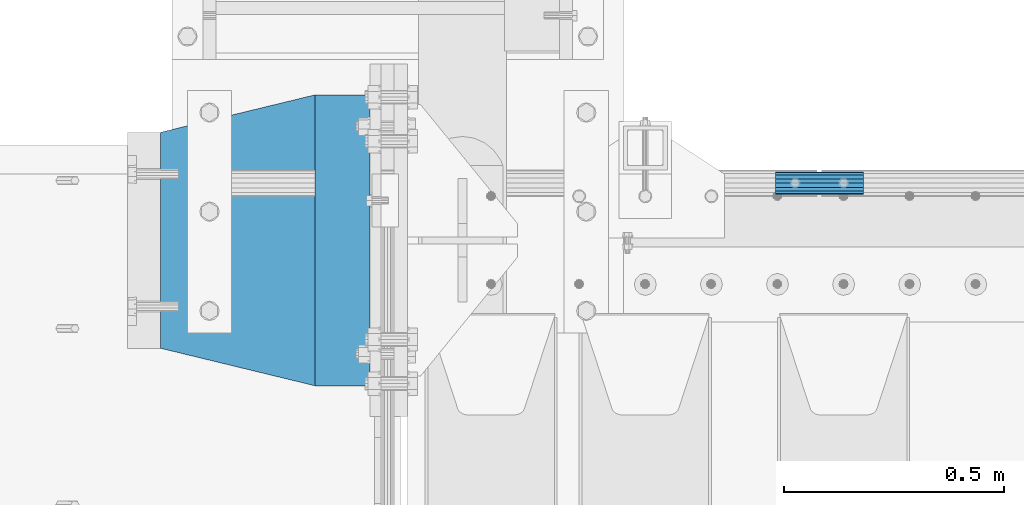
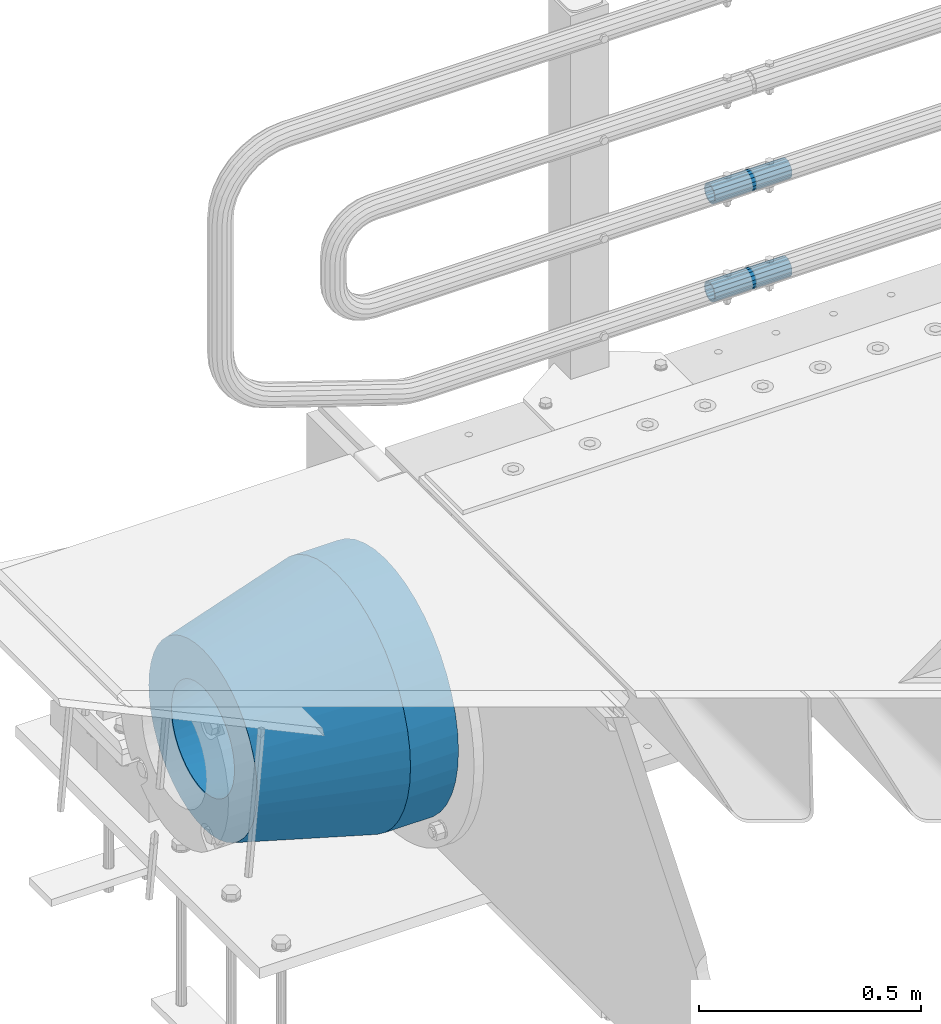
# One storey, part 152 of 257: 4 beams.
"""IFC2X3 building model written with IfcOpenShell, lengths in millimetres."""

from ifc_helpers import new_model, si_unit, frame, origin_with_axes, place, context, subcontext, project, spatial, faceted_brep, material, type_object, element, save


model = new_model("IFC2X3")

# Units and contexts
model_context = context("Model", 3, precision=1e-05, world=origin_with_axes())
body_context = subcontext(model_context, "Body", "Model", "MODEL_VIEW")
ifc_project = project(units=[si_unit("LENGTHUNIT", "METRE", prefix="MILLI"), si_unit("AREAUNIT", "SQUARE_METRE"), si_unit("VOLUMEUNIT", "CUBIC_METRE"), si_unit("MASSUNIT", "GRAM", prefix="KILO"), si_unit("TIMEUNIT", "SECOND"), si_unit("PLANEANGLEUNIT", "RADIAN"), si_unit("SOLIDANGLEUNIT", "STERADIAN"), si_unit("THERMODYNAMICTEMPERATUREUNIT", "DEGREE_CELSIUS"), si_unit("LUMINOUSINTENSITYUNIT", "LUMEN")], contexts=[model_context])

# Site, building, storey
site_placement = place(None, origin_with_axes())
site = spatial("IfcSite", under=ifc_project, at=site_placement, CompositionType="ELEMENT")
building_placement = place(site_placement, origin_with_axes())
building = spatial("IfcBuilding", under=site, at=building_placement, Name="Standard", CompositionType="ELEMENT")
storey_placement = place(building_placement, origin_with_axes())
storey = spatial("IfcBuildingStorey", under=building, at=storey_placement, Name="Undefined", CompositionType="ELEMENT", Elevation=0.0)

# Beams
ifc_material_1 = material()
beam_type_1 = type_object("IfcBeamType", PredefinedType="NOTDEFINED")
beam_1_placement = place(storey_placement, frame((43294.9975029999, 12129.8500000004, 149.849999999725), z_axis=(0.0, 0.0, 1.0), x_axis=(1.0, 0.0, 0.0)))
element("IfcBeam", 1, at=beam_1_placement, inside=storey, type_object=beam_type_1, material=ifc_material_1, context=body_context, shape_type="Brep", body=[
    faceted_brep([(0.0, -21.8999999999996, 0.0), (0.0, -20.232961761998, 8.38076716879547), (200.0, -20.232961761998, 8.38076716879547), (200.0, -21.8999999999996, 0.0), (0.0, -15.4856385079856, 15.4856385079854), (200.0, -15.4856385079856, 15.4856385079854), (0.0, -8.3807671687955, 20.2329617619972), (200.0, -8.3807671687955, 20.2329617619972), (0.0, 0.0, 21.9), (200.0, 0.0, 21.9), (0.0, 8.3807671687955, 20.2329617619972), (200.0, 8.3807671687955, 20.2329617619972), (0.0, 15.4856385079856, 15.4856385079854), (200.0, 15.4856385079856, 15.4856385079854), (0.0, 20.232961761998, 8.38076716879547), (200.0, 20.232961761998, 8.38076716879547), (0.0, 21.8999999999996, 0.0), (200.0, 21.8999999999996, 0.0), (0.0, 20.232961761998, -8.38076716879547), (200.0, 20.232961761998, -8.38076716879547), (0.0, 15.4856385079856, -15.4856385079854), (200.0, 15.4856385079856, -15.4856385079854), (0.0, 8.3807671687955, -20.2329617619972), (200.0, 8.3807671687955, -20.2329617619972), (0.0, 0.0, -21.9), (200.0, 0.0, -21.9), (0.0, -8.3807671687955, -20.2329617619972), (200.0, -8.3807671687955, -20.2329617619972), (0.0, -15.4856385079856, -15.4856385079854), (200.0, -15.4856385079856, -15.4856385079854), (0.0, -20.232961761998, -8.38076716879547), (200.0, -20.232961761998, -8.38076716879547), (0.0, -25.5, 0.0), (0.0, -23.5589280790373, -9.7584275253098), (200.0, -23.5589280790373, -9.7584275253098), (200.0, -25.5, 0.0), (0.0, -18.0312229202573, -18.031222920257), (200.0, -18.0312229202573, -18.031222920257), (0.0, -9.75842752531025, -23.5589280790378), (200.0, -9.75842752531025, -23.5589280790378), (0.0, 0.0, -25.5), (200.0, 0.0, -25.5), (0.0, 9.75842752531025, -23.5589280790378), (200.0, 9.75842752531025, -23.5589280790378), (0.0, 18.0312229202573, -18.031222920257), (200.0, 18.0312229202573, -18.031222920257), (0.0, 23.5589280790373, -9.7584275253098), (200.0, 23.5589280790373, -9.7584275253098), (0.0, 25.5, 0.0), (200.0, 25.5, 0.0), (0.0, 23.5589280790373, 9.7584275253098), (200.0, 23.5589280790373, 9.7584275253098), (0.0, 18.0312229202573, 18.031222920257), (200.0, 18.0312229202573, 18.031222920257), (0.0, 9.75842752531025, 23.5589280790378), (200.0, 9.75842752531025, 23.5589280790378), (0.0, 0.0, 25.5), (200.0, 0.0, 25.5), (0.0, -9.75842752531025, 23.5589280790378), (200.0, -9.75842752531025, 23.5589280790378), (0.0, -18.0312229202573, 18.031222920257), (200.0, -18.0312229202573, 18.031222920257), (0.0, -23.5589280790373, 9.7584275253098), (200.0, -23.5589280790373, 9.7584275253098)], [[[0, 1, 2, 3]], [[1, 4, 5, 2]], [[4, 6, 7, 5]], [[6, 8, 9, 7]], [[8, 10, 11, 9]], [[10, 12, 13, 11]], [[12, 14, 15, 13]], [[14, 16, 17, 15]], [[16, 18, 19, 17]], [[18, 20, 21, 19]], [[20, 22, 23, 21]], [[22, 24, 25, 23]], [[24, 26, 27, 25]], [[26, 28, 29, 27]], [[28, 30, 31, 29]], [[30, 0, 3, 31]], [[32, 33, 34, 35]], [[33, 36, 37, 34]], [[36, 38, 39, 37]], [[38, 40, 41, 39]], [[40, 42, 43, 41]], [[42, 44, 45, 43]], [[44, 46, 47, 45]], [[46, 48, 49, 47]], [[48, 50, 51, 49]], [[50, 52, 53, 51]], [[52, 54, 55, 53]], [[54, 56, 57, 55]], [[56, 58, 59, 57]], [[58, 60, 61, 59]], [[60, 62, 63, 61]], [[62, 32, 35, 63]], [[37, 39, 41, 43, 45, 47, 49, 51, 53, 55, 57, 59, 61, 63, 35, 34], [5, 7, 9, 11, 13, 15, 17, 19, 21, 23, 25, 27, 29, 31, 3, 2]], [[62, 60, 58, 56, 54, 52, 50, 48, 46, 44, 42, 40, 38, 36, 33, 32], [30, 28, 26, 24, 22, 20, 18, 16, 14, 12, 10, 8, 6, 4, 1, 0]]]),
])
beam_2_placement = place(storey_placement, frame((43294.9975029999, 12129.8500000004, 420.149999999724), z_axis=(0.0, 0.0, 1.0), x_axis=(1.0, 0.0, 0.0)))
element("IfcBeam", 2, at=beam_2_placement, inside=storey, type_object=beam_type_1, material=ifc_material_1, context=body_context, shape_type="Brep", body=[
    faceted_brep([(0.0, -21.8999999999996, 0.0), (0.0, -20.232961761998, 8.38076716879547), (200.0, -20.232961761998, 8.38076716879547), (200.0, -21.8999999999996, 0.0), (0.0, -15.4856385079856, 15.4856385079854), (200.0, -15.4856385079856, 15.4856385079854), (0.0, -8.3807671687955, 20.2329617619972), (200.0, -8.3807671687955, 20.2329617619972), (0.0, 0.0, 21.9), (200.0, 0.0, 21.9), (0.0, 8.3807671687955, 20.2329617619972), (200.0, 8.3807671687955, 20.2329617619972), (0.0, 15.4856385079856, 15.4856385079854), (200.0, 15.4856385079856, 15.4856385079854), (0.0, 20.232961761998, 8.38076716879547), (200.0, 20.232961761998, 8.38076716879547), (0.0, 21.8999999999996, 0.0), (200.0, 21.8999999999996, 0.0), (0.0, 20.232961761998, -8.38076716879547), (200.0, 20.232961761998, -8.38076716879547), (0.0, 15.4856385079856, -15.4856385079854), (200.0, 15.4856385079856, -15.4856385079854), (0.0, 8.3807671687955, -20.2329617619972), (200.0, 8.3807671687955, -20.2329617619972), (0.0, 0.0, -21.9), (200.0, 0.0, -21.9), (0.0, -8.3807671687955, -20.2329617619972), (200.0, -8.3807671687955, -20.2329617619972), (0.0, -15.4856385079856, -15.4856385079854), (200.0, -15.4856385079856, -15.4856385079854), (0.0, -20.232961761998, -8.38076716879547), (200.0, -20.232961761998, -8.38076716879547), (0.0, -25.5, 0.0), (0.0, -23.5589280790373, -9.7584275253098), (200.0, -23.5589280790373, -9.7584275253098), (200.0, -25.5, 0.0), (0.0, -18.0312229202573, -18.031222920257), (200.0, -18.0312229202573, -18.031222920257), (0.0, -9.75842752531025, -23.5589280790378), (200.0, -9.75842752531025, -23.5589280790378), (0.0, 0.0, -25.5), (200.0, 0.0, -25.5), (0.0, 9.75842752531025, -23.5589280790378), (200.0, 9.75842752531025, -23.5589280790378), (0.0, 18.0312229202573, -18.031222920257), (200.0, 18.0312229202573, -18.031222920257), (0.0, 23.5589280790373, -9.7584275253098), (200.0, 23.5589280790373, -9.7584275253098), (0.0, 25.5, 0.0), (200.0, 25.5, 0.0), (0.0, 23.5589280790373, 9.7584275253098), (200.0, 23.5589280790373, 9.7584275253098), (0.0, 18.0312229202573, 18.031222920257), (200.0, 18.0312229202573, 18.031222920257), (0.0, 9.75842752531025, 23.5589280790378), (200.0, 9.75842752531025, 23.5589280790378), (0.0, 0.0, 25.5), (200.0, 0.0, 25.5), (0.0, -9.75842752531025, 23.5589280790378), (200.0, -9.75842752531025, 23.5589280790378), (0.0, -18.0312229202573, 18.031222920257), (200.0, -18.0312229202573, 18.031222920257), (0.0, -23.5589280790373, 9.7584275253098), (200.0, -23.5589280790373, 9.7584275253098)], [[[0, 1, 2, 3]], [[1, 4, 5, 2]], [[4, 6, 7, 5]], [[6, 8, 9, 7]], [[8, 10, 11, 9]], [[10, 12, 13, 11]], [[12, 14, 15, 13]], [[14, 16, 17, 15]], [[16, 18, 19, 17]], [[18, 20, 21, 19]], [[20, 22, 23, 21]], [[22, 24, 25, 23]], [[24, 26, 27, 25]], [[26, 28, 29, 27]], [[28, 30, 31, 29]], [[30, 0, 3, 31]], [[32, 33, 34, 35]], [[33, 36, 37, 34]], [[36, 38, 39, 37]], [[38, 40, 41, 39]], [[40, 42, 43, 41]], [[42, 44, 45, 43]], [[44, 46, 47, 45]], [[46, 48, 49, 47]], [[48, 50, 51, 49]], [[50, 52, 53, 51]], [[52, 54, 55, 53]], [[54, 56, 57, 55]], [[56, 58, 59, 57]], [[58, 60, 61, 59]], [[60, 62, 63, 61]], [[62, 32, 35, 63]], [[37, 39, 41, 43, 45, 47, 49, 51, 53, 55, 57, 59, 61, 63, 35, 34], [5, 7, 9, 11, 13, 15, 17, 19, 21, 23, 25, 27, 29, 31, 3, 2]], [[62, 60, 58, 56, 54, 52, 50, 48, 46, 44, 42, 40, 38, 36, 33, 32], [30, 28, 26, 24, 22, 20, 18, 16, 14, 12, 10, 8, 6, 4, 1, 0]]]),
])
ifc_material_2 = material(Name="STEEL/S355N")
beam_type_2 = type_object("IfcBeamType", PredefinedType="NOTDEFINED")
beam_3_placement = place(storey_placement, frame((42375.0, 12000.0, -515.0), z_axis=(0.0, 0.0, 1.0), x_axis=(-1.0, 0.0, 0.0)))
element("IfcBeam", 3, at=beam_3_placement, inside=storey, type_object=beam_type_2, material=ifc_material_2, context=body_context, shape_type="Brep", body=[
    faceted_brep([(0.0, -215.0, 0.0), (0.0, -212.811610004401, 30.5976902287563), (125.0, -212.811610004401, 30.5976902287563), (125.0, -215.0, 0.0), (0.0, -206.290989327117, 60.5724997209074), (125.0, -206.290989327117, 60.5724997209074), (0.0, -195.570879001221, 89.3142277954056), (125.0, -195.570879001221, 89.3142277954056), (0.0, -180.869509558704, 116.237775752953), (125.0, -180.869509558704, 116.237775752953), (0.0, -162.486158486166, 140.795057798236), (125.0, -162.486158486166, 140.795057798236), (0.0, -140.795057798236, 162.486158486165), (125.0, -140.795057798236, 162.486158486165), (0.0, -116.237775752953, 180.869509558704), (125.0, -116.237775752953, 180.869509558704), (0.0, -89.3142277954055, 195.570879001222), (125.0, -89.3142277954055, 195.570879001222), (0.0, -60.5724997209073, 206.290989327117), (125.0, -60.5724997209073, 206.290989327117), (0.0, -30.5976902287562, 212.811610004401), (125.0, -30.5976902287562, 212.811610004401), (0.0, 3.94948592725021e-14, 215.0), (125.0, 3.94948592725021e-14, 215.0), (0.0, 30.5976902287563, 212.811610004401), (125.0, 30.5976902287563, 212.811610004401), (0.0, 60.5724997209074, 206.290989327117), (125.0, 60.5724997209074, 206.290989327117), (0.0, 89.3142277954056, 195.570879001221), (125.0, 89.3142277954056, 195.570879001221), (0.0, 116.237775752953, 180.869509558704), (125.0, 116.237775752953, 180.869509558704), (0.0, 140.795057798236, 162.486158486165), (125.0, 140.795057798236, 162.486158486165), (0.0, 162.486158486166, 140.795057798236), (125.0, 162.486158486166, 140.795057798236), (0.0, 180.869509558704, 116.237775752953), (125.0, 180.869509558704, 116.237775752953), (0.0, 195.570879001221, 89.3142277954056), (125.0, 195.570879001221, 89.3142277954056), (0.0, 206.290989327117, 60.5724997209073), (125.0, 206.290989327117, 60.5724997209073), (0.0, 212.811610004401, 30.5976902287563), (125.0, 212.811610004401, 30.5976902287563), (0.0, 215.0, 0.0), (125.0, 215.0, 0.0), (0.0, 212.811610004401, -30.5976902287563), (125.0, 212.811610004401, -30.5976902287563), (0.0, 206.290989327117, -60.5724997209073), (125.0, 206.290989327117, -60.5724997209073), (0.0, 195.570879001221, -89.3142277954056), (125.0, 195.570879001221, -89.3142277954056), (0.0, 180.869509558704, -116.237775752954), (125.0, 180.869509558704, -116.237775752954), (0.0, 162.486158486165, -140.795057798236), (125.0, 162.486158486165, -140.795057798236), (0.0, 140.795057798236, -162.486158486166), (125.0, 140.795057798236, -162.486158486166), (0.0, 116.237775752953, -180.869509558704), (125.0, 116.237775752953, -180.869509558704), (0.0, 89.3142277954056, -195.570879001221), (125.0, 89.3142277954056, -195.570879001221), (0.0, 60.5724997209074, -206.290989327117), (125.0, 60.5724997209074, -206.290989327117), (0.0, 30.5976902287563, -212.811610004401), (125.0, 30.5976902287563, -212.811610004401), (0.0, -1.3164953090834e-14, -215.0), (125.0, -1.3164953090834e-14, -215.0), (0.0, -30.5976902287563, -212.811610004401), (125.0, -30.5976902287563, -212.811610004401), (0.0, -60.5724997209074, -206.290989327117), (125.0, -60.5724997209074, -206.290989327117), (0.0, -89.3142277954056, -195.570879001221), (125.0, -89.3142277954056, -195.570879001221), (0.0, -116.237775752954, -180.869509558704), (125.0, -116.237775752954, -180.869509558704), (0.0, -140.795057798236, -162.486158486166), (125.0, -140.795057798236, -162.486158486166), (0.0, -162.486158486166, -140.795057798236), (125.0, -162.486158486166, -140.795057798236), (0.0, -180.869509558704, -116.237775752953), (125.0, -180.869509558704, -116.237775752953), (0.0, -195.570879001221, -89.3142277954056), (125.0, -195.570879001221, -89.3142277954056), (0.0, -206.290989327117, -60.5724997209073), (125.0, -206.290989327117, -60.5724997209073), (0.0, -212.811610004401, -30.5976902287563), (125.0, -212.811610004401, -30.5976902287563), (0.0, -330.0, 0.0), (0.0, -326.641075820708, -46.9638966301842), (125.0, -326.641075820708, -46.9638966301842), (125.0, -330.0, 0.0), (0.0, -316.632681292784, -92.9717437576718), (125.0, -316.632681292784, -92.9717437576718), (0.0, -300.178558466991, -137.086954290623), (125.0, -300.178558466991, -137.086954290623), (0.0, -277.61366583429, -178.411469760347), (125.0, -277.61366583429, -178.411469760347), (0.0, -249.397359536905, -216.104042201944), (125.0, -249.397359536905, -216.104042201944), (0.0, -216.104042201944, -249.397359536905), (125.0, -216.104042201944, -249.397359536905), (0.0, -178.411469760347, -277.61366583429), (125.0, -178.411469760347, -277.61366583429), (0.0, -137.086954290622, -300.178558466991), (125.0, -137.086954290622, -300.178558466991), (0.0, -92.9717437576717, -316.632681292784), (125.0, -92.9717437576717, -316.632681292784), (0.0, -46.963896630184, -326.641075820708), (125.0, -46.963896630184, -326.641075820708), (0.0, 6.0620016557794e-14, -330.0), (125.0, 6.0620016557794e-14, -330.0), (0.0, 46.9638966301841, -326.641075820708), (125.0, 46.9638966301841, -326.641075820708), (0.0, 92.9717437576718, -316.632681292784), (125.0, 92.9717437576718, -316.632681292784), (0.0, 137.086954290623, -300.178558466991), (125.0, 137.086954290623, -300.178558466991), (0.0, 178.411469760347, -277.61366583429), (125.0, 178.411469760347, -277.61366583429), (0.0, 216.104042201944, -249.397359536905), (125.0, 216.104042201944, -249.397359536905), (0.0, 249.397359536905, -216.104042201944), (125.0, 249.397359536905, -216.104042201944), (0.0, 277.61366583429, -178.411469760347), (125.0, 277.61366583429, -178.411469760347), (0.0, 300.178558466991, -137.086954290623), (125.0, 300.178558466991, -137.086954290623), (0.0, 316.632681292784, -92.9717437576717), (125.0, 316.632681292784, -92.9717437576717), (0.0, 326.641075820708, -46.9638966301841), (125.0, 326.641075820708, -46.9638966301841), (0.0, 330.0, 0.0), (125.0, 330.0, 0.0), (0.0, 326.641075820708, 46.9638966301841), (125.0, 326.641075820708, 46.9638966301841), (0.0, 316.632681292784, 92.9717437576718), (125.0, 316.632681292784, 92.9717437576718), (0.0, 300.178558466991, 137.086954290622), (125.0, 300.178558466991, 137.086954290622), (0.0, 277.61366583429, 178.411469760347), (125.0, 277.61366583429, 178.411469760347), (0.0, 249.397359536905, 216.104042201944), (125.0, 249.397359536905, 216.104042201944), (0.0, 216.104042201944, 249.397359536905), (125.0, 216.104042201944, 249.397359536905), (0.0, 178.411469760347, 277.61366583429), (125.0, 178.411469760347, 277.61366583429), (0.0, 137.086954290622, 300.178558466991), (125.0, 137.086954290622, 300.178558466991), (0.0, 92.9717437576718, 316.632681292784), (125.0, 92.9717437576718, 316.632681292784), (0.0, 46.9638966301841, 326.641075820708), (125.0, 46.9638966301841, 326.641075820708), (0.0, -2.02066721859313e-14, 330.0), (125.0, -2.02066721859313e-14, 330.0), (0.0, -46.9638966301841, 326.641075820708), (125.0, -46.9638966301841, 326.641075820708), (0.0, -92.9717437576718, 316.632681292784), (125.0, -92.9717437576718, 316.632681292784), (0.0, -137.086954290623, 300.178558466991), (125.0, -137.086954290623, 300.178558466991), (0.0, -178.411469760347, 277.61366583429), (125.0, -178.411469760347, 277.61366583429), (0.0, -216.104042201944, 249.397359536905), (125.0, -216.104042201944, 249.397359536905), (0.0, -249.397359536905, 216.104042201944), (125.0, -249.397359536905, 216.104042201944), (0.0, -277.61366583429, 178.411469760347), (125.0, -277.61366583429, 178.411469760347), (0.0, -300.178558466991, 137.086954290623), (125.0, -300.178558466991, 137.086954290623), (0.0, -316.632681292784, 92.9717437576718), (125.0, -316.632681292784, 92.9717437576718), (0.0, -326.641075820708, 46.9638966301841), (125.0, -326.641075820708, 46.9638966301841)], [[[0, 1, 2, 3]], [[1, 4, 5, 2]], [[4, 6, 7, 5]], [[6, 8, 9, 7]], [[8, 10, 11, 9]], [[10, 12, 13, 11]], [[12, 14, 15, 13]], [[14, 16, 17, 15]], [[16, 18, 19, 17]], [[18, 20, 21, 19]], [[20, 22, 23, 21]], [[22, 24, 25, 23]], [[24, 26, 27, 25]], [[26, 28, 29, 27]], [[28, 30, 31, 29]], [[30, 32, 33, 31]], [[32, 34, 35, 33]], [[34, 36, 37, 35]], [[36, 38, 39, 37]], [[38, 40, 41, 39]], [[40, 42, 43, 41]], [[42, 44, 45, 43]], [[44, 46, 47, 45]], [[46, 48, 49, 47]], [[48, 50, 51, 49]], [[50, 52, 53, 51]], [[52, 54, 55, 53]], [[54, 56, 57, 55]], [[56, 58, 59, 57]], [[58, 60, 61, 59]], [[60, 62, 63, 61]], [[62, 64, 65, 63]], [[64, 66, 67, 65]], [[66, 68, 69, 67]], [[68, 70, 71, 69]], [[70, 72, 73, 71]], [[72, 74, 75, 73]], [[74, 76, 77, 75]], [[76, 78, 79, 77]], [[78, 80, 81, 79]], [[80, 82, 83, 81]], [[82, 84, 85, 83]], [[84, 86, 87, 85]], [[86, 0, 3, 87]], [[88, 89, 90, 91]], [[89, 92, 93, 90]], [[92, 94, 95, 93]], [[94, 96, 97, 95]], [[96, 98, 99, 97]], [[98, 100, 101, 99]], [[100, 102, 103, 101]], [[102, 104, 105, 103]], [[104, 106, 107, 105]], [[106, 108, 109, 107]], [[108, 110, 111, 109]], [[110, 112, 113, 111]], [[112, 114, 115, 113]], [[114, 116, 117, 115]], [[116, 118, 119, 117]], [[118, 120, 121, 119]], [[120, 122, 123, 121]], [[122, 124, 125, 123]], [[124, 126, 127, 125]], [[126, 128, 129, 127]], [[128, 130, 131, 129]], [[130, 132, 133, 131]], [[132, 134, 135, 133]], [[134, 136, 137, 135]], [[136, 138, 139, 137]], [[138, 140, 141, 139]], [[140, 142, 143, 141]], [[142, 144, 145, 143]], [[144, 146, 147, 145]], [[146, 148, 149, 147]], [[148, 150, 151, 149]], [[150, 152, 153, 151]], [[152, 154, 155, 153]], [[154, 156, 157, 155]], [[156, 158, 159, 157]], [[158, 160, 161, 159]], [[160, 162, 163, 161]], [[162, 164, 165, 163]], [[164, 166, 167, 165]], [[166, 168, 169, 167]], [[168, 170, 171, 169]], [[170, 172, 173, 171]], [[172, 174, 175, 173]], [[174, 88, 91, 175]], [[93, 95, 97, 99, 101, 103, 105, 107, 109, 111, 113, 115, 117, 119, 121, 123, 125, 127, 129, 131, 133, 135, 137, 139, 141, 143, 145, 147, 149, 151, 153, 155, 157, 159, 161, 163, 165, 167, 169, 171, 173, 175, 91, 90], [5, 7, 9, 11, 13, 15, 17, 19, 21, 23, 25, 27, 29, 31, 33, 35, 37, 39, 41, 43, 45, 47, 49, 51, 53, 55, 57, 59, 61, 63, 65, 67, 69, 71, 73, 75, 77, 79, 81, 83, 85, 87, 3, 2]], [[174, 172, 170, 168, 166, 164, 162, 160, 158, 156, 154, 152, 150, 148, 146, 144, 142, 140, 138, 136, 134, 132, 130, 128, 126, 124, 122, 120, 118, 116, 114, 112, 110, 108, 106, 104, 102, 100, 98, 96, 94, 92, 89, 88], [86, 84, 82, 80, 78, 76, 74, 72, 70, 68, 66, 64, 62, 60, 58, 56, 54, 52, 50, 48, 46, 44, 42, 40, 38, 36, 34, 32, 30, 28, 26, 24, 22, 20, 18, 16, 14, 12, 10, 8, 6, 4, 1, 0]]]),
])
ifc_material_3 = material(Name="SCN-500-E2")
beam_type_3 = type_object("IfcBeamType", PredefinedType="NOTDEFINED")
beam_4_placement = place(storey_placement, frame((42250.0, 12000.0, -515.0), z_axis=(0.0, 0.0, 1.0), x_axis=(-1.0, 0.0, 0.0)))
element("IfcBeam", 4, at=beam_4_placement, inside=storey, type_object=beam_type_3, material=ifc_material_3, context=body_context, shape_type="Brep", body=[
    faceted_brep([(0.0, -330.0, 0.0), (0.0, -326.641075820708, -46.9638966301842), (350.0, -242.506253260829, -34.8671353769549), (350.0, -245.0, 0.0), (0.0, -316.632681292784, -92.9717437576718), (350.0, -235.075778535552, -69.0244764261503), (0.0, -300.178558466991, -137.086954290623), (350.0, -222.859838861857, -101.776678185462), (0.0, -277.61366583429, -178.411469760347), (350.0, -206.107115543639, -132.457000276621), (0.0, -249.397359536905, -216.104042201944), (350.0, -185.158645716793, -160.440879816595), (0.0, -216.104042201944, -249.397359536905), (350.0, -160.440879816595, -185.158645716793), (0.0, -178.411469760347, -277.61366583429), (350.0, -132.457000276621, -206.107115543639), (0.0, -137.086954290622, -300.178558466991), (350.0, -101.776678185462, -222.859838861857), (0.0, -92.9717437576717, -316.632681292784), (350.0, -69.0244764261502, -235.075778535552), (0.0, -46.963896630184, -326.641075820708), (350.0, -34.8671353769548, -242.506253260829), (0.0, 6.0620016557794e-14, -330.0), (350.0, 4.50057698686652e-14, -245.0), (0.0, 46.9638966301841, -326.641075820708), (350.0, 34.8671353769549, -242.506253260829), (0.0, 92.9717437576718, -316.632681292784), (350.0, 69.0244764261503, -235.075778535552), (0.0, 137.086954290623, -300.178558466991), (350.0, 101.776678185462, -222.859838861857), (0.0, 178.411469760347, -277.61366583429), (350.0, 132.457000276621, -206.107115543639), (0.0, 216.104042201944, -249.397359536905), (350.0, 160.440879816595, -185.158645716793), (0.0, 249.397359536905, -216.104042201944), (350.0, 185.158645716793, -160.440879816595), (0.0, 277.61366583429, -178.411469760347), (350.0, 206.107115543639, -132.457000276621), (0.0, 300.178558466991, -137.086954290623), (350.0, 222.859838861857, -101.776678185462), (0.0, 316.632681292784, -92.9717437576717), (350.0, 235.075778535552, -69.0244764261502), (0.0, 326.641075820708, -46.9638966301841), (350.0, 242.506253260829, -34.8671353769548), (0.0, 330.0, 0.0), (350.0, 245.0, 0.0), (0.0, 326.641075820708, 46.9638966301841), (350.0, 242.506253260829, 34.8671353769549), (0.0, 316.632681292784, 92.9717437576718), (350.0, 235.075778535552, 69.0244764261503), (0.0, 300.178558466991, 137.086954290622), (350.0, 222.859838861857, 101.776678185462), (0.0, 277.61366583429, 178.411469760347), (350.0, 206.107115543639, 132.457000276621), (0.0, 249.397359536905, 216.104042201944), (350.0, 185.158645716793, 160.440879816595), (0.0, 216.104042201944, 249.397359536905), (350.0, 160.440879816595, 185.158645716793), (0.0, 178.411469760347, 277.61366583429), (350.0, 132.457000276621, 206.107115543639), (0.0, 137.086954290622, 300.178558466991), (350.0, 101.776678185462, 222.859838861857), (0.0, 92.9717437576718, 316.632681292784), (350.0, 69.0244764261503, 235.075778535552), (0.0, 46.9638966301841, 326.641075820708), (350.0, 34.8671353769548, 242.506253260829), (0.0, -2.02066721859313e-14, 330.0), (350.0, -1.50019232895551e-14, 245.0), (0.0, -46.9638966301841, 326.641075820708), (350.0, -34.8671353769549, 242.506253260829), (0.0, -92.9717437576718, 316.632681292784), (350.0, -69.0244764261503, 235.075778535552), (0.0, -137.086954290623, 300.178558466991), (350.0, -101.776678185462, 222.859838861857), (0.0, -178.411469760347, 277.61366583429), (350.0, -132.457000276621, 206.107115543639), (0.0, -216.104042201944, 249.397359536905), (350.0, -160.440879816595, 185.158645716793), (0.0, -249.397359536905, 216.104042201944), (350.0, -185.158645716793, 160.440879816595), (0.0, -277.61366583429, 178.411469760347), (350.0, -206.107115543639, 132.457000276621), (0.0, -300.178558466991, 137.086954290623), (350.0, -222.859838861857, 101.776678185462), (0.0, -316.632681292784, 92.9717437576718), (350.0, -235.075778535552, 69.0244764261503), (0.0, -326.641075820708, 46.9638966301841), (350.0, -242.506253260829, 34.8671353769549), (0.0, -227.093265923131, 0.0), (0.0, -224.781783917484, 32.3187414128026), (350.0, -140.646961357605, 20.2219801595734), (350.0, -142.093265923131, 0.0), (0.0, -217.894393008413, 63.9795664499945), (350.0, -136.337490251181, 40.032299118473), (0.0, -206.571300613232, 94.3379520160985), (350.0, -129.252581008098, 59.0276759109381), (0.0, -191.043012240005, 122.775888927343), (350.0, -119.536461949355, 76.8214194436173), (0.0, -171.625639060125, 148.714462796454), (350.0, -107.386925240013, 93.0513004111044), (0.0, -148.714462796454, 171.625639060125), (350.0, -93.0513004111044, 107.386925240013), (0.0, -122.775888927343, 191.043012240005), (350.0, -76.8214194436173, 119.536461949355), (0.0, -94.3379520160984, 206.571300613232), (350.0, -59.0276759109381, 129.252581008098), (0.0, -63.9795664499945, 217.894393008413), (350.0, -40.032299118473, 136.337490251181), (0.0, -32.3187414128025, 224.781783917484), (350.0, -20.2219801595733, 140.646961357605), (0.0, 4.17163561831022e-14, 227.093265923131), (350.0, 2.61021094939735e-14, 142.093265923131), (0.0, 32.3187414128026, 224.781783917484), (350.0, 20.2219801595734, 140.646961357605), (0.0, 63.9795664499945, 217.894393008413), (350.0, 40.032299118473, 136.337490251181), (0.0, 94.3379520160985, 206.571300613232), (350.0, 59.0276759109381, 129.252581008098), (0.0, 122.775888927343, 191.043012240005), (350.0, 76.8214194436174, 119.536461949355), (0.0, 148.714462796454, 171.625639060125), (350.0, 93.0513004111044, 107.386925240013), (0.0, 171.625639060125, 148.714462796454), (350.0, 107.386925240013, 93.0513004111044), (0.0, 191.043012240005, 122.775888927343), (350.0, 119.536461949355, 76.8214194436174), (0.0, 206.571300613232, 94.3379520160985), (350.0, 129.252581008098, 59.0276759109382), (0.0, 217.894393008413, 63.9795664499945), (350.0, 136.337490251181, 40.032299118473), (0.0, 224.781783917484, 32.3187414128025), (350.0, 140.646961357605, 20.2219801595733), (0.0, 227.093265923131, 0.0), (350.0, 142.093265923131, 0.0), (0.0, 224.781783917484, -32.3187414128026), (350.0, 140.646961357605, -20.2219801595734), (0.0, 217.894393008413, -63.9795664499945), (350.0, 136.337490251181, -40.032299118473), (0.0, 206.571300613232, -94.3379520160985), (350.0, 129.252581008098, -59.0276759109381), (0.0, 191.043012240005, -122.775888927343), (350.0, 119.536461949355, -76.8214194436174), (0.0, 171.625639060125, -148.714462796454), (350.0, 107.386925240013, -93.0513004111044), (0.0, 148.714462796454, -171.625639060125), (350.0, 93.0513004111044, -107.386925240013), (0.0, 122.775888927343, -191.043012240005), (350.0, 76.8214194436174, -119.536461949355), (0.0, 94.3379520160985, -206.571300613232), (350.0, 59.0276759109381, -129.252581008098), (0.0, 63.9795664499945, -217.894393008413), (350.0, 40.032299118473, -136.337490251181), (0.0, 32.3187414128026, -224.781783917484), (350.0, 20.2219801595733, -140.646961357605), (0.0, -1.39054520610341e-14, -227.093265923131), (350.0, -8.70070316465783e-15, -142.093265923131), (0.0, -32.3187414128026, -224.781783917484), (350.0, -20.2219801595733, -140.646961357605), (0.0, -63.9795664499946, -217.894393008413), (350.0, -40.032299118473, -136.337490251181), (0.0, -94.3379520160985, -206.571300613232), (350.0, -59.0276759109381, -129.252581008098), (0.0, -122.775888927343, -191.043012240005), (350.0, -76.8214194436174, -119.536461949355), (0.0, -148.714462796454, -171.625639060125), (350.0, -93.0513004111044, -107.386925240013), (0.0, -171.625639060125, -148.714462796454), (350.0, -107.386925240013, -93.0513004111044), (0.0, -191.043012240005, -122.775888927343), (350.0, -119.536461949355, -76.8214194436174), (0.0, -206.571300613232, -94.3379520160985), (350.0, -129.252581008098, -59.0276759109381), (0.0, -217.894393008413, -63.9795664499945), (350.0, -136.337490251181, -40.032299118473), (0.0, -224.781783917484, -32.3187414128026), (350.0, -140.646961357605, -20.2219801595734)], [[[0, 1, 2, 3]], [[1, 4, 5, 2]], [[4, 6, 7, 5]], [[6, 8, 9, 7]], [[8, 10, 11, 9]], [[10, 12, 13, 11]], [[12, 14, 15, 13]], [[14, 16, 17, 15]], [[16, 18, 19, 17]], [[18, 20, 21, 19]], [[20, 22, 23, 21]], [[22, 24, 25, 23]], [[24, 26, 27, 25]], [[26, 28, 29, 27]], [[28, 30, 31, 29]], [[30, 32, 33, 31]], [[32, 34, 35, 33]], [[34, 36, 37, 35]], [[36, 38, 39, 37]], [[38, 40, 41, 39]], [[40, 42, 43, 41]], [[42, 44, 45, 43]], [[44, 46, 47, 45]], [[46, 48, 49, 47]], [[48, 50, 51, 49]], [[50, 52, 53, 51]], [[52, 54, 55, 53]], [[54, 56, 57, 55]], [[56, 58, 59, 57]], [[58, 60, 61, 59]], [[60, 62, 63, 61]], [[62, 64, 65, 63]], [[64, 66, 67, 65]], [[66, 68, 69, 67]], [[68, 70, 71, 69]], [[70, 72, 73, 71]], [[72, 74, 75, 73]], [[74, 76, 77, 75]], [[76, 78, 79, 77]], [[78, 80, 81, 79]], [[80, 82, 83, 81]], [[82, 84, 85, 83]], [[84, 86, 87, 85]], [[86, 0, 3, 87]], [[88, 89, 90, 91]], [[89, 92, 93, 90]], [[92, 94, 95, 93]], [[94, 96, 97, 95]], [[96, 98, 99, 97]], [[98, 100, 101, 99]], [[100, 102, 103, 101]], [[102, 104, 105, 103]], [[104, 106, 107, 105]], [[106, 108, 109, 107]], [[108, 110, 111, 109]], [[110, 112, 113, 111]], [[112, 114, 115, 113]], [[114, 116, 117, 115]], [[116, 118, 119, 117]], [[118, 120, 121, 119]], [[120, 122, 123, 121]], [[122, 124, 125, 123]], [[124, 126, 127, 125]], [[126, 128, 129, 127]], [[128, 130, 131, 129]], [[130, 132, 133, 131]], [[132, 134, 135, 133]], [[134, 136, 137, 135]], [[136, 138, 139, 137]], [[138, 140, 141, 139]], [[140, 142, 143, 141]], [[142, 144, 145, 143]], [[144, 146, 147, 145]], [[146, 148, 149, 147]], [[148, 150, 151, 149]], [[150, 152, 153, 151]], [[152, 154, 155, 153]], [[154, 156, 157, 155]], [[156, 158, 159, 157]], [[158, 160, 161, 159]], [[160, 162, 163, 161]], [[162, 164, 165, 163]], [[164, 166, 167, 165]], [[166, 168, 169, 167]], [[168, 170, 171, 169]], [[170, 172, 173, 171]], [[172, 174, 175, 173]], [[174, 88, 91, 175]], [[5, 7, 9, 11, 13, 15, 17, 19, 21, 23, 25, 27, 29, 31, 33, 35, 37, 39, 41, 43, 45, 47, 49, 51, 53, 55, 57, 59, 61, 63, 65, 67, 69, 71, 73, 75, 77, 79, 81, 83, 85, 87, 3, 2], [93, 95, 97, 99, 101, 103, 105, 107, 109, 111, 113, 115, 117, 119, 121, 123, 125, 127, 129, 131, 133, 135, 137, 139, 141, 143, 145, 147, 149, 151, 153, 155, 157, 159, 161, 163, 165, 167, 169, 171, 173, 175, 91, 90]], [[86, 84, 82, 80, 78, 76, 74, 72, 70, 68, 66, 64, 62, 60, 58, 56, 54, 52, 50, 48, 46, 44, 42, 40, 38, 36, 34, 32, 30, 28, 26, 24, 22, 20, 18, 16, 14, 12, 10, 8, 6, 4, 1, 0], [174, 172, 170, 168, 166, 164, 162, 160, 158, 156, 154, 152, 150, 148, 146, 144, 142, 140, 138, 136, 134, 132, 130, 128, 126, 124, 122, 120, 118, 116, 114, 112, 110, 108, 106, 104, 102, 100, 98, 96, 94, 92, 89, 88]]]),
])

save(model, "model.ifc")
